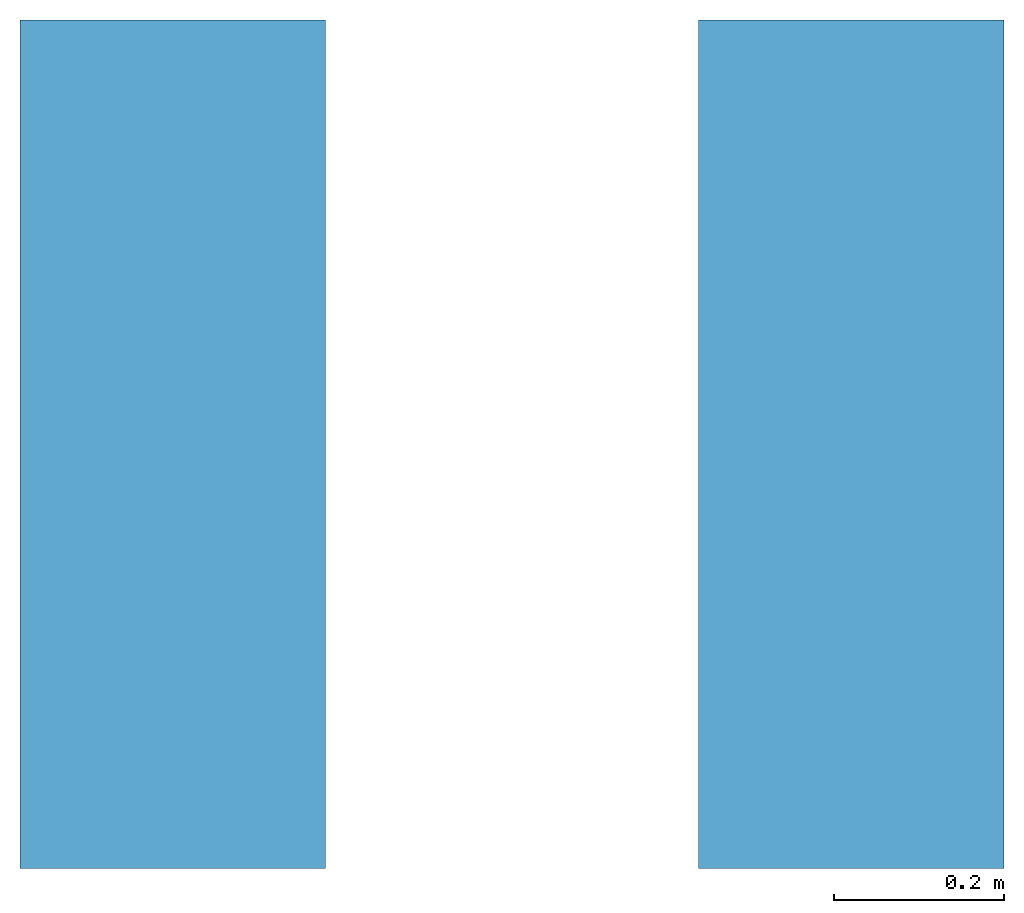
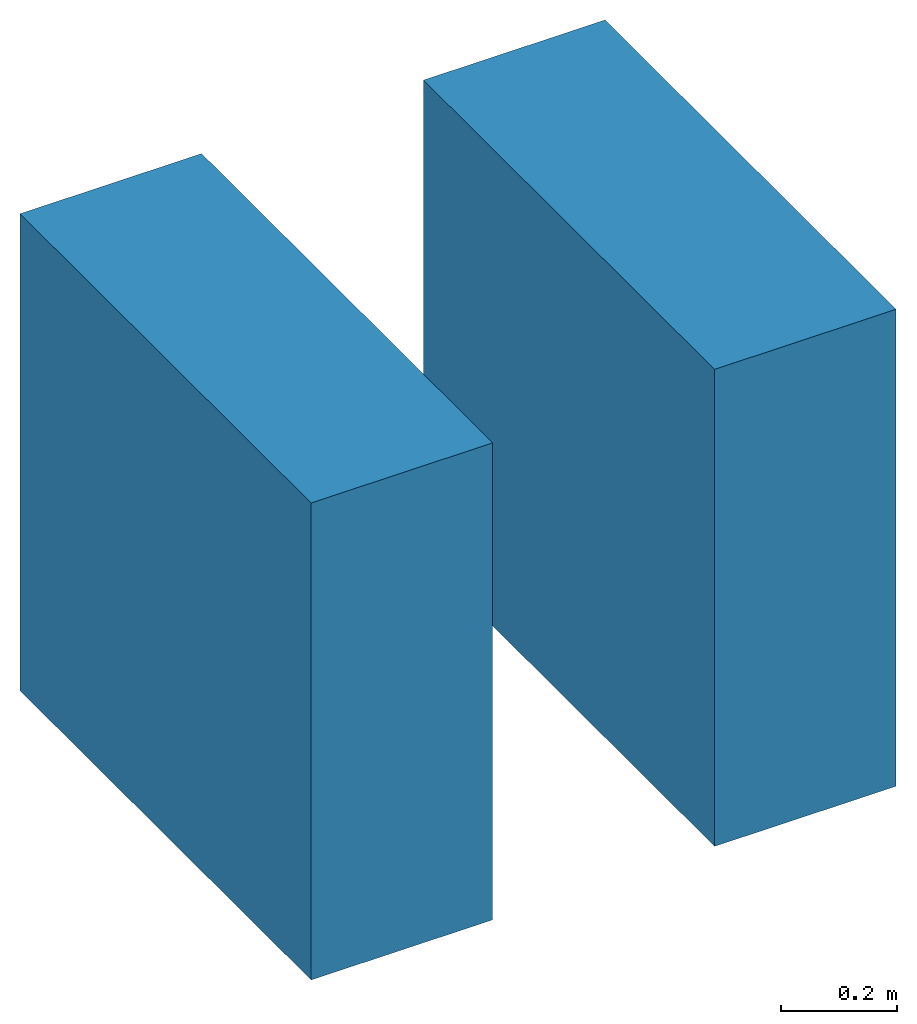
# One storey: 2 walls.
"""IFC2X3 building model written with IfcOpenShell, lengths in millimetres."""

from ifc_helpers import new_model, entity, si_unit, converted_unit, derived_unit, direction, frame, frame_2d, origin, place, context, subcontext, project, spatial, rectangle, extrude, material, layer, layer_set, layer_usage, type_object, element, save


model = new_model("IFC2X3")

# Units and contexts
model_context = context("Model", 3, precision=0.01, world=origin(), true_north=direction((6.12303176911189e-17, 1.0)))
context_of_model = context(None, 3, precision=0.01, world=origin(), true_north=direction((6.12303176911189e-17, 1.0)))
body_context = subcontext(model_context, "Body", "Model", "MODEL_VIEW")
ifc_project = project(units=[si_unit("LENGTHUNIT", "METRE", prefix="MILLI"), si_unit("AREAUNIT", "SQUARE_METRE"), si_unit("VOLUMEUNIT", "CUBIC_METRE"), converted_unit("PLANEANGLEUNIT", "DEGREE", entity("IfcRatioMeasure", 0.0174532925199433), si_unit("PLANEANGLEUNIT", "RADIAN"), dimensions=[0, 0, 0, 0, 0, 0, 0]), si_unit("MASSUNIT", "GRAM", prefix="KILO"), si_unit("TIMEUNIT", "SECOND"), si_unit("FREQUENCYUNIT", "HERTZ"), si_unit("THERMODYNAMICTEMPERATUREUNIT", "DEGREE_CELSIUS"), derived_unit("THERMALTRANSMITTANCEUNIT", [(si_unit("MASSUNIT", "GRAM", prefix="KILO"), 1), (si_unit("THERMODYNAMICTEMPERATUREUNIT", "KELVIN"), -1), (si_unit("TIMEUNIT", "SECOND"), -3)]), derived_unit("VOLUMETRICFLOWRATEUNIT", [(si_unit("LENGTHUNIT", "METRE"), 3), (si_unit("TIMEUNIT", "SECOND"), -1)]), si_unit("ELECTRICCURRENTUNIT", "AMPERE"), si_unit("ELECTRICVOLTAGEUNIT", "VOLT"), si_unit("POWERUNIT", "WATT"), si_unit("FORCEUNIT", "NEWTON", prefix="KILO"), si_unit("ILLUMINANCEUNIT", "LUX"), si_unit("LUMINOUSFLUXUNIT", "LUMEN"), si_unit("LUMINOUSINTENSITYUNIT", "CANDELA"), si_unit("PRESSUREUNIT", "PASCAL")], contexts=[model_context, context_of_model])

# Site, building, storey
site_placement = place(None, origin())
site = spatial("IfcSite", under=ifc_project, at=site_placement, CompositionType="ELEMENT")
building_placement = place(site_placement, origin())
building = spatial("IfcBuilding", under=site, at=building_placement, CompositionType="ELEMENT")
storey_placement = place(building_placement, origin())
storey = spatial("IfcBuildingStorey", under=building, at=storey_placement, CompositionType="ELEMENT", Elevation=0.0)

# Walls
ifc_material_1 = material()
ifc_layer_1 = layer(ifc_material_1, 10.0)
ifc_material_2 = material()
ifc_layer_2 = layer(ifc_material_2, 1.0)
ifc_material_3 = material()
ifc_layer_3 = layer(ifc_material_3, 10.0)
ifc_material_4 = material()
ifc_layer_4 = layer(ifc_material_4, 100.0)
ifc_material_5 = material()
ifc_layer_5 = layer(ifc_material_5, 9.0)
ifc_material_6 = material()
ifc_layer_6 = layer(ifc_material_6, 10.0)
ifc_material_7 = material()
ifc_layer_7 = layer(ifc_material_7, 200.0)
ifc_material_8 = material()
ifc_layer_8 = layer(ifc_material_8, 20.0)
ifc_layer_set_1 = layer_set([ifc_layer_1, ifc_layer_2, ifc_layer_3, ifc_layer_4, ifc_layer_5, ifc_layer_6, ifc_layer_7, ifc_layer_8])
ifc_layer_usage_1 = layer_usage(ifc_layer_set_1, "AXIS2", "POSITIVE", -180.0)
wall_type_1 = type_object("IfcWallType", PredefinedType="STANDARD", material=ifc_layer_set_1)
wall_1_placement = place(storey_placement, frame((2631.90671950462, 3044.93365683083, 0.0), z_axis=(0.0, 0.0, 1.0), x_axis=(0.0, -1.0, 0.0)))
element("IfcWallStandardCase", 1, at=wall_1_placement, inside=storey, type_object=wall_type_1, material=ifc_layer_usage_1, context=body_context, shape_type="SweptSolid", body=[
    extrude(rectangle(XDim=1000.0, YDim=360.0, at=frame_2d((500.0, 0.0), x_axis=(-1.0, 0.0))), origin(), (0.0, 0.0, 1.0), 1000.0),
])
ifc_layer_9 = layer(ifc_material_1, 10.0)
ifc_layer_10 = layer(ifc_material_2, 1.0)
ifc_layer_11 = layer(ifc_material_3, 10.0)
ifc_material_9 = material()
ifc_layer_12 = layer(ifc_material_9, 100.0)
ifc_layer_13 = layer(ifc_material_5, 9.0)
ifc_layer_14 = layer(ifc_material_6, 10.0)
ifc_layer_15 = layer(ifc_material_7, 200.0)
ifc_layer_16 = layer(ifc_material_8, 20.0)
ifc_layer_set_2 = layer_set([ifc_layer_9, ifc_layer_10, ifc_layer_11, ifc_layer_12, ifc_layer_13, ifc_layer_14, ifc_layer_15, ifc_layer_16])
ifc_layer_usage_2 = layer_usage(ifc_layer_set_2, "AXIS2", "POSITIVE", -180.0)
wall_type_2 = type_object("IfcWallType", PredefinedType="STANDARD", material=ifc_layer_set_2)
wall_2_placement = place(storey_placement, frame((3431.90671950462, 3044.93365683083, 0.0), z_axis=(0.0, 0.0, 1.0), x_axis=(0.0, -1.0, 0.0)))
element("IfcWallStandardCase", 2, at=wall_2_placement, inside=storey, type_object=wall_type_2, material=ifc_layer_usage_2, context=body_context, shape_type="SweptSolid", body=[
    extrude(rectangle(XDim=1000.0, YDim=360.0, at=frame_2d((500.0, 0.0), x_axis=(-1.0, 0.0))), origin(), (0.0, 0.0, 1.0), 1000.0),
])

save(model, "model.ifc")
